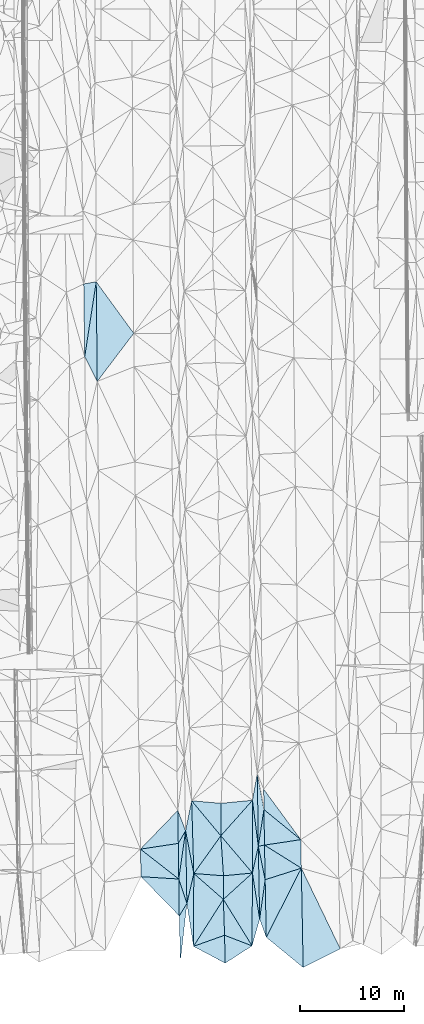
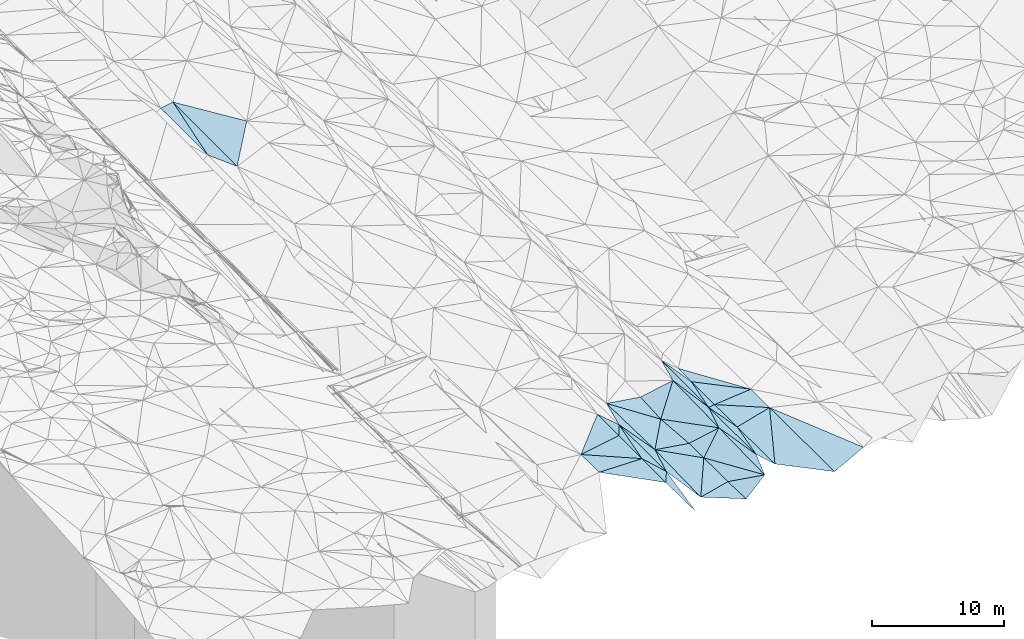
# One storey, part 23 of 275: 45 plates.
"""IFC2X3 building model written with IfcOpenShell, lengths in millimetres."""

from ifc_helpers import new_model, si_unit, frame, origin_with_axes, place, context, subcontext, project, spatial, polyline, outline, extrude, material, type_object, element, save


model = new_model("IFC2X3")

# Units and contexts
model_context = context("Model", 3, precision=1e-05, world=origin_with_axes())
body_context = subcontext(model_context, "Body", "Model", "MODEL_VIEW")
ifc_project = project(units=[si_unit("LENGTHUNIT", "METRE", prefix="MILLI"), si_unit("AREAUNIT", "SQUARE_METRE"), si_unit("VOLUMEUNIT", "CUBIC_METRE"), si_unit("MASSUNIT", "GRAM", prefix="KILO"), si_unit("TIMEUNIT", "SECOND"), si_unit("PLANEANGLEUNIT", "RADIAN"), si_unit("SOLIDANGLEUNIT", "STERADIAN"), si_unit("THERMODYNAMICTEMPERATUREUNIT", "DEGREE_CELSIUS"), si_unit("LUMINOUSINTENSITYUNIT", "LUMEN")], contexts=[model_context])

# Site, building, storey
site_placement = place(None, origin_with_axes())
site = spatial("IfcSite", under=ifc_project, at=site_placement, CompositionType="ELEMENT")
building_placement = place(site_placement, origin_with_axes())
building = spatial("IfcBuilding", under=site, at=building_placement, Name="Undefined", CompositionType="ELEMENT")
storey_placement = place(building_placement, origin_with_axes())
storey = spatial("IfcBuildingStorey", under=building, at=storey_placement, Name="Undefined", CompositionType="ELEMENT", Elevation=0.0)

# Plates
ifc_material = material()
plate_type_1 = type_object("IfcPlateType", PredefinedType="NOTDEFINED")
plate_1_placement = place(storey_placement, frame((-77855.6958797632, -26842.6024537685, 40772.5003564228), z_axis=(-0.033095411914403, 0.0193857631481733, -0.999264172227434), x_axis=(-0.152939120437254, 0.987938493469123, 0.0242313549319789)))
element("IfcPlate", 1, at=plate_1_placement, inside=storey, type_object=plate_type_1, material=ifc_material, Name="00", context=body_context, shape_type="SweptSolid", body=[
    extrude(outline(polyline([(0.0, 0.0), (4168.1533203125, 1.86264514923096e-09), (6918.4853515625, 1097.97338867188), (0.0, 0.0)])), frame((-8.85201319254618e-08, 2.18876761149539e-07, -0.5000001331573), z_axis=(0.0, 0.0, 1.0), x_axis=(1.0, 0.0, 0.0)), (0.0, 0.0, 1.0), 1.0),
])
plate_type_2 = type_object("IfcPlateType", PredefinedType="NOTDEFINED")
plate_2_placement = place(storey_placement, frame((-77855.7211969945, -26842.6145906234, 40772.5017499971), z_axis=(-0.0837460979317346, -0.0048636463274129, -0.996475256103036), x_axis=(0.93848230797332, 0.335810797561215, -0.0805112778582659)))
element("IfcPlate", 2, at=plate_2_placement, inside=storey, type_object=plate_type_2, material=ifc_material, Name="00", context=body_context, shape_type="SweptSolid", body=[
    extrude(outline(polyline([(0.0, 0.0), (3179.6787109375, 5.58247847948223e-09), (2334.474609375, 2548.92016601563), (0.0, 0.0)])), frame((-8.85201319254618e-08, 2.18876761149539e-07, -0.5000001331573), z_axis=(0.0, 0.0, 1.0), x_axis=(1.0, 0.0, 0.0)), (0.0, 0.0, 1.0), 1.0),
])
plate_type_3 = type_object("IfcPlateType", PredefinedType="NOTDEFINED")
plate_3_placement = place(storey_placement, frame((-79274.0806693137, -20367.1746317346, 40909.5004607387), z_axis=(0.0371895373784289, 0.0230456718728641, -0.999042459216577), x_axis=(0.0132180246697055, -0.999657930020083, -0.0225678260316448)))
element("IfcPlate", 3, at=plate_3_placement, inside=storey, type_object=plate_type_3, material=ifc_material, Name="00", context=body_context, shape_type="SweptSolid", body=[
    extrude(outline(polyline([(0.0, 0.0), (3544.86962890625, -8.73114913702011e-10), (-266.328552246094, 3628.7421875), (0.0, 0.0)])), frame((-8.85201319254618e-08, 2.18876761149539e-07, -0.5000001331573), z_axis=(0.0, 0.0, 1.0), x_axis=(1.0, 0.0, 0.0)), (0.0, 0.0, 1.0), 1.0),
])
plate_type_4 = type_object("IfcPlateType", PredefinedType="NOTDEFINED")
plate_4_placement = place(storey_placement, frame((-71497.0149106165, -24222.795486387, 40919.5004961251), z_axis=(-0.0398771542731156, 0.0213925396553267, -0.998975561169628), x_axis=(-0.0181141316664564, 0.999591013586829, 0.0221288000222636)))
element("IfcPlate", 4, at=plate_4_placement, inside=storey, type_object=plate_type_4, material=ifc_material, Name="00", context=body_context, shape_type="SweptSolid", body=[
    extrude(outline(polyline([(0.0, 0.0), (7004.44677734375, -7.04312697052956e-09), (3778.73461914063, 598.349670410156), (0.0, 0.0)])), frame((-8.85201319254618e-08, 2.18876761149539e-07, -0.5000001331573), z_axis=(0.0, 0.0, 1.0), x_axis=(1.0, 0.0, 0.0)), (0.0, 0.0, 1.0), 1.0),
])
plate_type_5 = type_object("IfcPlateType", PredefinedType="NOTDEFINED")
plate_5_placement = place(storey_placement, frame((-77829.3709402771, -19838.886317341, 40907.501097027), z_axis=(-0.0647328261765514, 0.0154924246653393, -0.997782364041971), x_axis=(-0.188330011545863, 0.981721795944408, 0.0274612839980644)))
element("IfcPlate", 5, at=plate_5_placement, inside=storey, type_object=plate_type_5, material=ifc_material, Name="00", context=body_context, shape_type="SweptSolid", body=[
    extrude(outline(polyline([(0.0, 0.0), (4187.7138671875, 8.14907252788544e-10), (6906.92578125, 1116.12890625), (0.0, 0.0)])), frame((-8.85201319254618e-08, 2.18876761149539e-07, -0.5000001331573), z_axis=(0.0, 0.0, 1.0), x_axis=(1.0, 0.0, 0.0)), (0.0, 0.0, 1.0), 1.0),
])
plate_type_6 = type_object("IfcPlateType", PredefinedType="NOTDEFINED")
plate_6_placement = place(storey_placement, frame((-78618.0011551694, -15727.7133152952, 41022.5001916065), z_axis=(0.0192150721586178, 0.0216287812629123, -0.999581400798865), x_axis=(0.0178375636637127, -0.999614276621159, -0.0212865990167345)))
element("IfcPlate", 6, at=plate_6_placement, inside=storey, type_object=plate_type_6, material=ifc_material, Name="00", context=body_context, shape_type="SweptSolid", body=[
    extrude(outline(polyline([(0.0, 0.0), (6999.708984375, 2.53203324973583e-09), (4628.375, 738.901428222656), (0.0, 0.0)])), frame((-8.85201319254618e-08, 2.18876761149539e-07, -0.5000001331573), z_axis=(0.0, 0.0, 1.0), x_axis=(1.0, 0.0, 0.0)), (0.0, 0.0, 1.0), 1.0),
])
plate_type_7 = type_object("IfcPlateType", PredefinedType="NOTDEFINED")
plate_7_placement = place(storey_placement, frame((-88318.7910822436, 29860.7643873985, 41740.5001281014), z_axis=(0.0135979427870087, 0.0199769013971401, -0.99970796703964), x_axis=(0.151373224421463, 0.988236114447613, 0.0218066281147447)))
element("IfcPlate", 7, at=plate_7_placement, inside=storey, type_object=plate_type_7, material=ifc_material, Name="00", context=body_context, shape_type="SweptSolid", body=[
    extrude(outline(polyline([(0.0, 0.0), (7291.36083984375, -1.16560840979218e-08), (-2161.79174804688, 1549.96850585938), (0.0, 0.0)])), frame((-8.85201319254618e-08, 2.18876761149539e-07, -0.5000001331573), z_axis=(0.0, 0.0, 1.0), x_axis=(1.0, 0.0, 0.0)), (0.0, 0.0, 1.0), 1.0),
])
plate_type_8 = type_object("IfcPlateType", PredefinedType="NOTDEFINED")
plate_8_placement = place(storey_placement, frame((-71623.8973660095, -17221.214263376, 41074.5006067428), z_axis=(-0.0458371674567032, 0.0196819527366252, -0.998755012410961), x_axis=(0.150292055395648, 0.988561557494762, 0.0125835260750638)))
element("IfcPlate", 8, at=plate_8_placement, inside=storey, type_object=plate_type_8, material=ifc_material, Name="00", context=body_context, shape_type="SweptSolid", body=[
    extrude(outline(polyline([(0.0, 0.0), (3576.10424804688, 6.14090822637081e-09), (204.144485473633, 571.127868652344), (0.0, 0.0)])), frame((-8.85201319254618e-08, 2.18876761149539e-07, -0.5000001331573), z_axis=(0.0, 0.0, 1.0), x_axis=(1.0, 0.0, 0.0)), (0.0, 0.0, 1.0), 1.0),
])
plate_type_9 = type_object("IfcPlateType", PredefinedType="NOTDEFINED")
plate_9_placement = place(storey_placement, frame((-71086.4392700437, -13686.0147237305, 41119.5007072906), z_axis=(-0.0497807695671621, 0.0202789475085021, -0.99855427457362), x_axis=(-0.150292055394831, -0.988561557494829, -0.0125835260795822)))
element("IfcPlate", 9, at=plate_9_placement, inside=storey, type_object=plate_type_9, material=ifc_material, Name="00", context=body_context, shape_type="SweptSolid", body=[
    extrude(outline(polyline([(0.0, 0.0), (3576.10424804688, 6.14090822637081e-09), (-3328.9501953125, 1150.23120117188), (0.0, 0.0)])), frame((-8.85201319254618e-08, 2.18876761149539e-07, -0.5000001331573), z_axis=(0.0, 0.0, 1.0), x_axis=(1.0, 0.0, 0.0)), (0.0, 0.0, 1.0), 1.0),
])
plate_type_10 = type_object("IfcPlateType", PredefinedType="NOTDEFINED")
plate_10_placement = place(storey_placement, frame((-71029.176936046, -17104.8038131413, 41049.500402141), z_axis=(-0.0347167280782452, 0.0211819655185762, -0.999172694346834), x_axis=(0.988399856173153, 0.14863653956921, -0.0311913998047732)))
element("IfcPlate", 10, at=plate_10_placement, inside=storey, type_object=plate_type_10, material=ifc_material, Name="00", context=body_context, shape_type="SweptSolid", body=[
    extrude(outline(polyline([(0.0, 0.0), (3526.61303710938, -1.44609657581896e-09), (3173.72485351563, 2720.9501953125), (0.0, 0.0)])), frame((-8.85201319254618e-08, 2.18876761149539e-07, -0.5000001331573), z_axis=(0.0, 0.0, 1.0), x_axis=(1.0, 0.0, 0.0)), (0.0, 0.0, 1.0), 1.0),
])
plate_11_placement = place(storey_placement, frame((-74810.820337492, -28459.5414804406, 40524.5035992951), z_axis=(0.119968344629757, -0.00024469578476659, -0.992777687305053), x_axis=(-0.0226136825509938, 0.999739839398053, -0.00297907399008728)))
element("IfcPlate", 11, at=plate_11_placement, inside=storey, type_object=plate_type_10, material=ifc_material, Name="00", context=body_context, shape_type="SweptSolid", body=[
    extrude(outline(polyline([(0.0, 0.0), (2685.39819335938, -4.05998434871435e-09), (1605.75207519531, 2641.36938476563), (0.0, 0.0)])), frame((-8.85201319254618e-08, 2.18876761149539e-07, -0.5000001331573), z_axis=(0.0, 0.0, 1.0), x_axis=(1.0, 0.0, 0.0)), (0.0, 0.0, 1.0), 1.0),
])
plate_type_11 = type_object("IfcPlateType", PredefinedType="NOTDEFINED")
plate_12_placement = place(storey_placement, frame((-78493.1721763449, -22724.7228803627, 40873.500461501), z_axis=(-0.0383433297001515, 0.0205904197820008, -0.999052462927101), x_axis=(-0.0178375635316432, 0.999614276623936, 0.0212865989970147)))
element("IfcPlate", 12, at=plate_12_placement, inside=storey, type_object=plate_type_11, material=ifc_material, Name="00", context=body_context, shape_type="SweptSolid", body=[
    extrude(outline(polyline([(0.0, 0.0), (6999.708984375, 2.53203324973583e-09), (2873.60888671875, 715.712890625), (0.0, 0.0)])), frame((-8.85201319254618e-08, 2.18876761149539e-07, -0.5000001331573), z_axis=(0.0, 0.0, 1.0), x_axis=(1.0, 0.0, 0.0)), (0.0, 0.0, 1.0), 1.0),
])
plate_type_12 = type_object("IfcPlateType", PredefinedType="NOTDEFINED")
plate_13_placement = place(storey_placement, frame((-79368.7672431156, -13772.3030256395, 41049.5002324783), z_axis=(0.0223576649135496, 0.0223850226259977, -0.999499397489387), x_axis=(0.358403135514181, -0.933477936474616, -0.0128893199469879)))
element("IfcPlate", 13, at=plate_13_placement, inside=storey, type_object=plate_type_12, material=ifc_material, Name="00", context=body_context, shape_type="SweptSolid", body=[
    extrude(outline(polyline([(0.0, 0.0), (2094.75756835938, 3.37604433298111e-09), (2978.62158203125, 1093.94384765625), (0.0, 0.0)])), frame((-8.85201319254618e-08, 2.18876761149539e-07, -0.5000001331573), z_axis=(0.0, 0.0, 1.0), x_axis=(1.0, 0.0, 0.0)), (0.0, 0.0, 1.0), 1.0),
])
plate_type_13 = type_object("IfcPlateType", PredefinedType="NOTDEFINED")
plate_14_placement = place(storey_placement, frame((-71623.7911505075, -17221.2125910866, 41074.5071102668), z_axis=(0.166597117976748, 0.0230386989947293, -0.985755861575508), x_axis=(-0.126567595564065, 0.991956364182143, 0.00179312901802421)))
element("IfcPlate", 14, at=plate_14_placement, inside=storey, type_object=plate_type_13, material=ifc_material, Name="00", context=body_context, shape_type="SweptSolid", body=[
    extrude(outline(polyline([(0.0, 0.0), (4461.47607421875, 1.00480974651873e-08), (6954.34326171875, 799.949768066406), (0.0, 0.0)])), frame((-8.85201319254618e-08, 2.18876761149539e-07, -0.5000001331573), z_axis=(0.0, 0.0, 1.0), x_axis=(1.0, 0.0, 0.0)), (0.0, 0.0, 1.0), 1.0),
])
plate_type_14 = type_object("IfcPlateType", PredefinedType="NOTDEFINED")
plate_15_placement = place(storey_placement, frame((-74985.6070153125, -22326.5048611658, 40667.5032578217), z_axis=(0.112643869316624, -0.0186240469920938, -0.99346087168998), x_axis=(0.00598911346132977, 0.999818891903969, -0.0180641609787954)))
element("IfcPlate", 15, at=plate_15_placement, inside=storey, type_object=plate_type_14, material=ifc_material, Name="00", context=body_context, shape_type="SweptSolid", body=[
    extrude(outline(polyline([(0.0, 0.0), (2269.6875, -1.73167791217566e-09), (2547.8447265625, 2794.38208007813), (0.0, 0.0)])), frame((-8.85201319254618e-08, 2.18876761149539e-07, -0.5000001331573), z_axis=(0.0, 0.0, 1.0), x_axis=(1.0, 0.0, 0.0)), (0.0, 0.0, 1.0), 1.0),
])
plate_type_15 = type_object("IfcPlateType", PredefinedType="NOTDEFINED")
plate_16_placement = place(storey_placement, frame((-77829.3881603102, -19838.9027542349, 40907.5025287368), z_axis=(-0.0991740370332565, -0.0173815474116761, -0.994918284176194), x_axis=(0.992333852326071, -0.0758246544790692, -0.0975917378717536)))
element("IfcPlate", 16, at=plate_16_placement, inside=storey, type_object=plate_type_15, material=ifc_material, Name="00", context=body_context, shape_type="SweptSolid", body=[
    extrude(outline(polyline([(0.0, 0.0), (2879.34204101563, -7.95989762991667e-09), (3033.91870117188, 2264.41748046875), (0.0, 0.0)])), frame((-8.85201319254618e-08, 2.18876761149539e-07, -0.5000001331573), z_axis=(0.0, 0.0, 1.0), x_axis=(1.0, 0.0, 0.0)), (0.0, 0.0, 1.0), 1.0),
])
plate_type_16 = type_object("IfcPlateType", PredefinedType="NOTDEFINED")
plate_17_placement = place(storey_placement, frame((-72225.5477975187, -26793.956314234, 40836.5010762002), z_axis=(0.0644252455107256, 0.0139548846897058, -0.997824959065557), x_axis=(0.00452874345366986, 0.999887834920917, 0.0142761360280655)))
element("IfcPlate", 17, at=plate_17_placement, inside=storey, type_object=plate_type_16, material=ifc_material, Name="00", context=body_context, shape_type="SweptSolid", body=[
    extrude(outline(polyline([(0.0, 0.0), (7004.6962890625, -4.52564563602209e-09), (2575.35327148438, 718.421813964844), (0.0, 0.0)])), frame((-8.85201319254618e-08, 2.18876761149539e-07, -0.5000001331573), z_axis=(0.0, 0.0, 1.0), x_axis=(1.0, 0.0, 0.0)), (0.0, 0.0, 1.0), 1.0),
])
plate_type_17 = type_object("IfcPlateType", PredefinedType="NOTDEFINED")
plate_18_placement = place(storey_placement, frame((-71110.0004458326, -11728.3748281446, 41169.500371023), z_axis=(-0.0302119965966342, 0.0251574759713925, -0.999226869466786), x_axis=(0.591819216411072, -0.805166696416169, -0.038165508890328)))
element("IfcPlate", 18, at=plate_18_placement, inside=storey, type_object=plate_type_17, material=ifc_material, Name="00", context=body_context, shape_type="SweptSolid", body=[
    extrude(outline(polyline([(0.0, 0.0), (6026.3837890625, 9.60426405072212e-09), (1592.08251953125, 1140.470703125), (0.0, 0.0)])), frame((-8.85201319254618e-08, 2.18876761149539e-07, -0.5000001331573), z_axis=(0.0, 0.0, 1.0), x_axis=(1.0, 0.0, 0.0)), (0.0, 0.0, 1.0), 1.0),
])
plate_type_18 = type_object("IfcPlateType", PredefinedType="NOTDEFINED")
plate_19_placement = place(storey_placement, frame((-79123.1943218423, -28325.7704882602, 40739.5002608361), z_axis=(0.0259955898751133, 0.0209865299572828, -0.999441741607482), x_axis=(-0.0235530626558573, 0.999514929511707, 0.0203754490192606)))
element("IfcPlate", 19, at=plate_19_placement, inside=storey, type_object=plate_type_18, material=ifc_material, Name="00", context=body_context, shape_type="SweptSolid", body=[
    extrude(outline(polyline([(0.0, 0.0), (4417.08056640625, -6.85395207256079e-09), (5586.2216796875, 762.095947265625), (0.0, 0.0)])), frame((-8.85201319254618e-08, 2.18876761149539e-07, -0.5000001331573), z_axis=(0.0, 0.0, 1.0), x_axis=(1.0, 0.0, 0.0)), (0.0, 0.0, 1.0), 1.0),
])
plate_20_placement = place(storey_placement, frame((-70967.6909339628, -20434.2515424513, 40979.500613451), z_axis=(-0.0459281768087278, 0.0201498037241235, -0.998741502083951), x_axis=(-0.200017944623415, 0.979364242674647, 0.0289568989869318)))
element("IfcPlate", 20, at=plate_20_placement, inside=storey, type_object=plate_type_18, material=ifc_material, Name="00", context=body_context, shape_type="SweptSolid", body=[
    extrude(outline(polyline([(0.0, 0.0), (3280.73803710938, 3.68163455277681e-09), (3275.06787109375, 606.489807128906), (0.0, 0.0)])), frame((-8.85201319254618e-08, 2.18876761149539e-07, -0.5000001331573), z_axis=(0.0, 0.0, 1.0), x_axis=(1.0, 0.0, 0.0)), (0.0, 0.0, 1.0), 1.0),
])
plate_type_19 = type_object("IfcPlateType", PredefinedType="NOTDEFINED")
plate_21_placement = place(storey_placement, frame((-72193.7840856635, -19790.0424241143, 40936.5055202208), z_axis=(0.146901939891898, 0.020531466156136, -0.988937955057584), x_axis=(0.000758266462155232, 0.99978192623181, 0.0208692360229906)))
element("IfcPlate", 21, at=plate_21_placement, inside=storey, type_object=plate_type_19, material=ifc_material, Name="00", context=body_context, shape_type="SweptSolid", body=[
    extrude(outline(polyline([(0.0, 0.0), (6995.94384765625, -7.47240846976638e-09), (2571.58056640625, 574.263488769531), (0.0, 0.0)])), frame((-8.85201319254618e-08, 2.18876761149539e-07, -0.5000001331573), z_axis=(0.0, 0.0, 1.0), x_axis=(1.0, 0.0, 0.0)), (0.0, 0.0, 1.0), 1.0),
])
plate_type_20 = type_object("IfcPlateType", PredefinedType="NOTDEFINED")
plate_22_placement = place(storey_placement, frame((-82903.5155905357, -20145.8103126562, 40779.5004644065), z_axis=(0.0372109465557981, 0.0234020185282223, -0.999033378313871), x_axis=(-0.0217524866509341, 0.999507847581099, 0.022602919021669)))
element("IfcPlate", 22, at=plate_22_placement, inside=storey, type_object=plate_type_20, material=ifc_material, Name="00", context=body_context, shape_type="SweptSolid", body=[
    extrude(outline(polyline([(0.0, 0.0), (2654.5244140625, -8.73114913702011e-11), (-297.266052246094, 3626.3388671875), (0.0, 0.0)])), frame((-8.85201319254618e-08, 2.18876761149539e-07, -0.5000001331573), z_axis=(0.0, 0.0, 1.0), x_axis=(1.0, 0.0, 0.0)), (0.0, 0.0, 1.0), 1.0),
])
plate_type_21 = type_object("IfcPlateType", PredefinedType="NOTDEFINED")
plate_23_placement = place(storey_placement, frame((-70858.744125949, -25973.1898214341, 40869.500236894), z_axis=(-0.0252228838304343, 0.0193532955014952, -0.999494500277269), x_axis=(-0.342452438561852, 0.93915208856692, 0.0268268869500915)))
element("IfcPlate", 23, at=plate_23_placement, inside=storey, type_object=plate_type_21, material=ifc_material, Name="00", context=body_context, shape_type="SweptSolid", body=[
    extrude(outline(polyline([(0.0, 0.0), (1863.8017578125, 2.27009877562523e-09), (5242.16162109375, 1795.42248535156), (0.0, 0.0)])), frame((-8.85201319254618e-08, 2.18876761149539e-07, -0.5000001331573), z_axis=(0.0, 0.0, 1.0), x_axis=(1.0, 0.0, 0.0)), (0.0, 0.0, 1.0), 1.0),
])
plate_type_22 = type_object("IfcPlateType", PredefinedType="NOTDEFINED")
plate_24_placement = place(storey_placement, frame((-79274.0877844012, -20367.1747208126, 40909.5002445214), z_axis=(0.0229587654083464, 0.0228672670043347, -0.999474853706024), x_axis=(0.314417484493332, -0.949174151361683, -0.0144939929527196)))
element("IfcPlate", 24, at=plate_24_placement, inside=storey, type_object=plate_type_22, material=ifc_material, Name="00", context=body_context, shape_type="SweptSolid", body=[
    extrude(outline(polyline([(0.0, 0.0), (2483.78759765625, -3.49245965480804e-10), (3379.439453125, 1070.27502441406), (0.0, 0.0)])), frame((-8.85201319254618e-08, 2.18876761149539e-07, -0.5000001331573), z_axis=(0.0, 0.0, 1.0), x_axis=(1.0, 0.0, 0.0)), (0.0, 0.0, 1.0), 1.0),
])
plate_type_23 = type_object("IfcPlateType", PredefinedType="NOTDEFINED")
plate_25_placement = place(storey_placement, frame((-71496.9297592527, -24222.7940366167, 40919.504409294), z_axis=(0.130429758441461, 0.0243057343224944, -0.99115957816688), x_axis=(-0.155299140536863, 0.987860224921203, 0.00378853100047694)))
element("IfcPlate", 25, at=plate_25_placement, inside=storey, type_object=plate_type_23, material=ifc_material, Name="00", context=body_context, shape_type="SweptSolid", body=[
    extrude(outline(polyline([(0.0, 0.0), (4487.2275390625, -1.42608769237995e-09), (6936.8759765625, 970.580810546875), (0.0, 0.0)])), frame((-8.85201319254618e-08, 2.18876761149539e-07, -0.5000001331573), z_axis=(0.0, 0.0, 1.0), x_axis=(1.0, 0.0, 0.0)), (0.0, 0.0, 1.0), 1.0),
])
plate_type_24 = type_object("IfcPlateType", PredefinedType="NOTDEFINED")
plate_26_placement = place(storey_placement, frame((-75201.092081701, -13084.3520568936, 40769.5023957516), z_axis=(-0.0875651220301761, 0.044034452178201, -0.995185066419913), x_axis=(-0.0087707684540865, -0.999017871529459, -0.0434323149909625)))
element("IfcPlate", 26, at=plate_26_placement, inside=storey, type_object=plate_type_24, material=ifc_material, Name="00", context=body_context, shape_type="SweptSolid", body=[
    extrude(outline(polyline([(0.0, 0.0), (3131.30908203125, -4.36557456851006e-11), (-224.069229125977, 2848.31494140625), (0.0, 0.0)])), frame((-8.85201319254618e-08, 2.18876761149539e-07, -0.5000001331573), z_axis=(0.0, 0.0, 1.0), x_axis=(1.0, 0.0, 0.0)), (0.0, 0.0, 1.0), 1.0),
])
plate_type_25 = type_object("IfcPlateType", PredefinedType="NOTDEFINED")
plate_27_placement = place(storey_placement, frame((-74985.7131821982, -22326.475430147, 40667.5028859701), z_axis=(-0.0996897330681453, 0.0402380315601238, -0.994204635845643), x_axis=(0.0330259535576184, -0.998497650267673, -0.0437233210260437)))
element("IfcPlate", 27, at=plate_27_placement, inside=storey, type_object=plate_type_25, material=ifc_material, Name="00", context=body_context, shape_type="SweptSolid", body=[
    extrude(outline(polyline([(0.0, 0.0), (3453.53466796875, 2.25554686039686e-09), (4409.9560546875, 3032.42724609375), (0.0, 0.0)])), frame((-8.85201319254618e-08, 2.18876761149539e-07, -0.5000001331573), z_axis=(0.0, 0.0, 1.0), x_axis=(1.0, 0.0, 0.0)), (0.0, 0.0, 1.0), 1.0),
])
plate_type_26 = type_object("IfcPlateType", PredefinedType="NOTDEFINED")
plate_28_placement = place(storey_placement, frame((-88318.7925798816, 29860.7646170594, 41740.5001145802), z_axis=(0.0106034422808835, 0.0204361798028466, -0.999734929652286), x_axis=(-0.0137492026408672, 0.999699600048951, 0.0202896300781234)))
element("IfcPlate", 28, at=plate_28_placement, inside=storey, type_object=plate_type_26, material=ifc_material, Name="00", context=body_context, shape_type="SweptSolid", body=[
    extrude(outline(polyline([(0.0, 0.0), (6998.64892578125, -2.22644302994013e-09), (7191.47265625, 1202.77514648438), (0.0, 0.0)])), frame((-8.85201319254618e-08, 2.18876761149539e-07, -0.5000001331573), z_axis=(0.0, 0.0, 1.0), x_axis=(1.0, 0.0, 0.0)), (0.0, 0.0, 1.0), 1.0),
])
plate_type_27 = type_object("IfcPlateType", PredefinedType="NOTDEFINED")
plate_29_placement = place(storey_placement, frame((-79368.7609103637, -13772.3029297343, 41049.500422106), z_axis=(0.035038675280852, 0.0225630743515077, -0.999131222067638), x_axis=(0.0146763875075118, -0.999648916697277, -0.0220600769647263)))
element("IfcPlate", 29, at=plate_29_placement, inside=storey, type_object=plate_type_27, material=ifc_material, Name="00", context=body_context, shape_type="SweptSolid", body=[
    extrude(outline(polyline([(0.0, 0.0), (3173.15307617188, -1.04773789644241e-09), (3670.89135742188, 3649.00756835938), (0.0, 0.0)])), frame((-8.85201319254618e-08, 2.18876761149539e-07, -0.5000001331573), z_axis=(0.0, 0.0, 1.0), x_axis=(1.0, 0.0, 0.0)), (0.0, 0.0, 1.0), 1.0),
])
plate_type_28 = type_object("IfcPlateType", PredefinedType="NOTDEFINED")
plate_30_placement = place(storey_placement, frame((-79274.0867107654, -20367.1757580355, 40909.5002477707), z_axis=(0.0251064545213819, 0.0207929037759799, -0.999468519311103), x_axis=(-0.0140509126637282, 0.999692247694972, 0.0204446020233064)))
element("IfcPlate", 30, at=plate_30_placement, inside=storey, type_object=plate_type_28, material=ifc_material, Name="00", context=body_context, shape_type="SweptSolid", body=[
    extrude(outline(polyline([(0.0, 0.0), (3423.88671875, -6.37373887002468e-09), (4631.1259765625, 721.458679199219), (0.0, 0.0)])), frame((-8.85201319254618e-08, 2.18876761149539e-07, -0.5000001331573), z_axis=(0.0, 0.0, 1.0), x_axis=(1.0, 0.0, 0.0)), (0.0, 0.0, 1.0), 1.0),
])
plate_type_29 = type_object("IfcPlateType", PredefinedType="NOTDEFINED")
plate_31_placement = place(storey_placement, frame((-67489.9662932521, -19323.1810070309, 40879.5003581568), z_axis=(-0.0326259604196101, 0.020310079486553, -0.999261250813794), x_axis=(0.434673031688406, -0.900002276178725, -0.0324847409705625)))
element("IfcPlate", 31, at=plate_31_placement, inside=storey, type_object=plate_type_29, material=ifc_material, Name="00", context=body_context, shape_type="SweptSolid", body=[
    extrude(outline(polyline([(0.0, 0.0), (8619.431640625, -2.68773874267936e-08), (8682.37109375, 3995.31469726563), (0.0, 0.0)])), frame((-8.85201319254618e-08, 2.18876761149539e-07, -0.5000001331573), z_axis=(0.0, 0.0, 1.0), x_axis=(1.0, 0.0, 0.0)), (0.0, 0.0, 1.0), 1.0),
])
plate_type_30 = type_object("IfcPlateType", PredefinedType="NOTDEFINED")
plate_32_placement = place(storey_placement, frame((-87215.0700557721, 37066.3507431017, 41899.500203614), z_axis=(0.0219812784310495, 0.0200623275241233, -0.999557065110768), x_axis=(0.589121532646521, -0.808037853766416, -0.00326292089682773)))
element("IfcPlate", 32, at=plate_32_placement, inside=storey, type_object=plate_type_30, material=ifc_material, Name="00", context=body_context, shape_type="SweptSolid", body=[
    extrude(outline(polyline([(0.0, 0.0), (6129.47802734375, 1.84736563824117e-08), (7798.673828125, 5562.83984375), (0.0, 0.0)])), frame((-8.85201319254618e-08, 2.18876761149539e-07, -0.5000001331573), z_axis=(0.0, 0.0, 1.0), x_axis=(1.0, 0.0, 0.0)), (0.0, 0.0, 1.0), 1.0),
])
plate_type_31 = type_object("IfcPlateType", PredefinedType="NOTDEFINED")
plate_33_placement = place(storey_placement, frame((-71086.4316410155, -13686.0149227535, 41119.5003812624), z_axis=(-0.034522097162634, 0.0198806844666048, -0.999206176518457), x_axis=(0.773806049519148, -0.632201446552037, -0.0393132128562664)))
element("IfcPlate", 33, at=plate_33_placement, inside=storey, type_object=plate_type_31, material=ifc_material, Name="00", context=body_context, shape_type="SweptSolid", body=[
    extrude(outline(polyline([(0.0, 0.0), (4578.61328125, -1.16197043098509e-08), (2208.41967773438, 2611.3564453125), (0.0, 0.0)])), frame((-8.85201319254618e-08, 2.18876761149539e-07, -0.5000001331573), z_axis=(0.0, 0.0, 1.0), x_axis=(1.0, 0.0, 0.0)), (0.0, 0.0, 1.0), 1.0),
])
plate_type_32 = type_object("IfcPlateType", PredefinedType="NOTDEFINED")
plate_34_placement = place(storey_placement, frame((-70858.7489407645, -25973.189919532, 40869.5003800583), z_axis=(-0.0348524606216054, 0.0191582343102801, -0.999208821041294), x_axis=(-0.0196597126645682, 0.999609627629272, 0.0198516510350018)))
element("IfcPlate", 34, at=plate_34_placement, inside=storey, type_object=plate_type_32, material=ifc_material, Name="00", context=body_context, shape_type="SweptSolid", body=[
    extrude(outline(polyline([(0.0, 0.0), (5541.10107421875, -8.42555891722441e-09), (6581.3818359375, 3500.9736328125), (0.0, 0.0)])), frame((-8.85201319254618e-08, 2.18876761149539e-07, -0.5000001331573), z_axis=(0.0, 0.0, 1.0), x_axis=(1.0, 0.0, 0.0)), (0.0, 0.0, 1.0), 1.0),
])
plate_type_33 = type_object("IfcPlateType", PredefinedType="NOTDEFINED")
plate_35_placement = place(storey_placement, frame((-67489.9684621391, -19323.1810485953, 40879.5004331385), z_axis=(-0.036960712377621, 0.0202260929208925, -0.999112011190785), x_axis=(0.0186471675392509, -0.999607116888856, -0.0209259410281103)))
element("IfcPlate", 35, at=plate_35_placement, inside=storey, type_object=plate_type_33, material=ifc_material, Name="00", context=body_context, shape_type="SweptSolid", body=[
    extrude(outline(polyline([(0.0, 0.0), (9557.515625, 1.70111889019609e-08), (6584.78662109375, 3494.56494140625), (0.0, 0.0)])), frame((-8.85201319254618e-08, 2.18876761149539e-07, -0.5000001331573), z_axis=(0.0, 0.0, 1.0), x_axis=(1.0, 0.0, 0.0)), (0.0, 0.0, 1.0), 1.0),
])
plate_type_34 = type_object("IfcPlateType", PredefinedType="NOTDEFINED")
plate_36_placement = place(storey_placement, frame((-71029.177194637, -17104.8042260926, 41049.5004025076), z_axis=(-0.035234173860626, 0.0203563571689376, -0.999171742852634), x_axis=(0.846611224494961, -0.530655959669295, -0.0406655508582163)))
element("IfcPlate", 36, at=plate_36_placement, inside=storey, type_object=plate_type_34, material=ifc_material, Name="00", context=body_context, shape_type="SweptSolid", body=[
    extrude(outline(polyline([(0.0, 0.0), (4180.4423828125, -2.46582203544676e-08), (1821.69702148438, 2788.42602539063), (0.0, 0.0)])), frame((-8.85201319254618e-08, 2.18876761149539e-07, -0.5000001331573), z_axis=(0.0, 0.0, 1.0), x_axis=(1.0, 0.0, 0.0)), (0.0, 0.0, 1.0), 1.0),
])
plate_type_35 = type_object("IfcPlateType", PredefinedType="NOTDEFINED")
plate_37_placement = place(storey_placement, frame((-74972.0149123523, -20057.2146104319, 40626.503044869), z_axis=(0.110020726059108, 0.00914817664301516, -0.993887192140806), x_axis=(-0.0665537655707274, 0.997781186395975, 0.00181669001114636)))
element("IfcPlate", 37, at=plate_37_placement, inside=storey, type_object=plate_type_35, material=ifc_material, Name="00", context=body_context, shape_type="SweptSolid", body=[
    extrude(outline(polyline([(0.0, 0.0), (3853.16088867188, -3.17231751978397e-09), (82.2363815307617, 2806.98754882813), (0.0, 0.0)])), frame((-8.85201319254618e-08, 2.18876761149539e-07, -0.5000001331573), z_axis=(0.0, 0.0, 1.0), x_axis=(1.0, 0.0, 0.0)), (0.0, 0.0, 1.0), 1.0),
])
plate_type_36 = type_object("IfcPlateType", PredefinedType="NOTDEFINED")
plate_38_placement = place(storey_placement, frame((-75228.4626728232, -16212.5865430683, 40633.502907465), z_axis=(0.0992349066759452, 0.0423500019944274, -0.99416241662421), x_axis=(0.00877076845361714, 0.999017871529039, 0.0434323150007147)))
element("IfcPlate", 38, at=plate_38_placement, inside=storey, type_object=plate_type_36, material=ifc_material, Name="00", context=body_context, shape_type="SweptSolid", body=[
    extrude(outline(polyline([(0.0, 0.0), (3131.30908203125, -4.36557456851006e-11), (3459.78125, 3024.6611328125), (0.0, 0.0)])), frame((-8.85201319254618e-08, 2.18876761149539e-07, -0.5000001331573), z_axis=(0.0, 0.0, 1.0), x_axis=(1.0, 0.0, 0.0)), (0.0, 0.0, 1.0), 1.0),
])
plate_type_37 = type_object("IfcPlateType", PredefinedType="NOTDEFINED")
plate_39_placement = place(storey_placement, frame((-72225.538298051, -26793.9563648983, 40836.5017800151), z_axis=(0.0834262355613961, 0.0138487332650739, -0.996417721544036), x_axis=(-0.525326357256377, 0.850292645405362, -0.0321657510606522)))
element("IfcPlate", 39, at=plate_39_placement, inside=storey, type_object=plate_type_37, material=ifc_material, Name="00", context=body_context, shape_type="SweptSolid", body=[
    extrude(outline(polyline([(0.0, 0.0), (5254.03564453125, 2.06637196242809e-08), (5935.49267578125, 3719.63696289063), (0.0, 0.0)])), frame((-8.85201319254618e-08, 2.18876761149539e-07, -0.5000001331573), z_axis=(0.0, 0.0, 1.0), x_axis=(1.0, 0.0, 0.0)), (0.0, 0.0, 1.0), 1.0),
])
plate_type_38 = type_object("IfcPlateType", PredefinedType="NOTDEFINED")
plate_40_placement = place(storey_placement, frame((-74985.6969086498, -22326.4858064247, 40667.5012120724), z_axis=(-0.0671497407809235, 0.0194808512307755, -0.997552709759429), x_axis=(-0.536256529484323, -0.843827013180178, 0.0196190319039853)))
element("IfcPlate", 40, at=plate_40_placement, inside=storey, type_object=plate_type_38, material=ifc_material, Name="00", context=body_context, shape_type="SweptSolid", body=[
    extrude(outline(polyline([(0.0, 0.0), (5351.94580078125, 1.0077201295644e-08), (-569.457336425781, 3742.72216796875), (0.0, 0.0)])), frame((-8.85201319254618e-08, 2.18876761149539e-07, -0.5000001331573), z_axis=(0.0, 0.0, 1.0), x_axis=(1.0, 0.0, 0.0)), (0.0, 0.0, 1.0), 1.0),
])
plate_type_39 = type_object("IfcPlateType", PredefinedType="NOTDEFINED")
plate_41_placement = place(storey_placement, frame((-75228.5614048982, -16212.610090416, 40633.5024121802), z_axis=(-0.0982311305457426, -0.00474028613078917, -0.995152337423323), x_axis=(0.0665537655718528, -0.997781186395893, -0.00181669001496357)))
element("IfcPlate", 41, at=plate_41_placement, inside=storey, type_object=plate_type_39, material=ifc_material, Name="00", context=body_context, shape_type="SweptSolid", body=[
    extrude(outline(polyline([(0.0, 0.0), (3853.16088867188, -3.17231751978397e-09), (3444.64770507813, 2850.21533203125), (0.0, 0.0)])), frame((-8.85201319254618e-08, 2.18876761149539e-07, -0.5000001331573), z_axis=(0.0, 0.0, 1.0), x_axis=(1.0, 0.0, 0.0)), (0.0, 0.0, 1.0), 1.0),
])
plate_type_40 = type_object("IfcPlateType", PredefinedType="NOTDEFINED")
plate_42_placement = place(storey_placement, frame((-82961.2590726918, -17492.5935364255, 40839.5004067794), z_axis=(0.0352857983853525, 0.0209296279953419, -0.999158077135087), x_axis=(0.988126107721543, 0.148868019512, 0.0380145762260796)))
element("IfcPlate", 42, at=plate_42_placement, inside=storey, type_object=plate_type_40, material=ifc_material, Name="00", context=body_context, shape_type="SweptSolid", body=[
    extrude(outline(polyline([(0.0, 0.0), (3682.7978515625, -7.77617970015854e-09), (3218.1240234375, 3392.20849609375), (0.0, 0.0)])), frame((-8.85201319254618e-08, 2.18876761149539e-07, -0.5000001331573), z_axis=(0.0, 0.0, 1.0), x_axis=(1.0, 0.0, 0.0)), (0.0, 0.0, 1.0), 1.0),
])
plate_type_41 = type_object("IfcPlateType", PredefinedType="NOTDEFINED")
plate_43_placement = place(storey_placement, frame((-75228.5740854171, -16212.6008843346, 40633.5038676215), z_axis=(-0.123571134185935, 0.0136538596651656, -0.992241778455355), x_axis=(-0.581717688577152, -0.811078742345868, 0.0612846188786493)))
element("IfcPlate", 43, at=plate_43_placement, inside=storey, type_object=plate_type_41, material=ifc_material, Name="00", context=body_context, shape_type="SweptSolid", body=[
    extrude(outline(polyline([(0.0, 0.0), (4470.9423828125, 5.18775777891278e-09), (-1072.5458984375, 4268.61865234375), (0.0, 0.0)])), frame((-8.85201319254618e-08, 2.18876761149539e-07, -0.5000001331573), z_axis=(0.0, 0.0, 1.0), x_axis=(1.0, 0.0, 0.0)), (0.0, 0.0, 1.0), 1.0),
])
plate_type_42 = type_object("IfcPlateType", PredefinedType="NOTDEFINED")
plate_44_placement = place(storey_placement, frame((-74871.5380352017, -25774.817747026, 40516.5053572911), z_axis=(0.138080881723207, 0.0478860429085491, -0.989262653190295), x_axis=(-0.033025953576171, 0.998497650268353, 0.0437233209964999)))
element("IfcPlate", 44, at=plate_44_placement, inside=storey, type_object=plate_type_42, material=ifc_material, Name="00", context=body_context, shape_type="SweptSolid", body=[
    extrude(outline(polyline([(0.0, 0.0), (3453.53466796875, 2.25554686039686e-09), (-1090.98657226563, 2636.70556640625), (0.0, 0.0)])), frame((-8.85201319254618e-08, 2.18876761149539e-07, -0.5000001331573), z_axis=(0.0, 0.0, 1.0), x_axis=(1.0, 0.0, 0.0)), (0.0, 0.0, 1.0), 1.0),
])
plate_type_43 = type_object("IfcPlateType", PredefinedType="NOTDEFINED")
plate_45_placement = place(storey_placement, frame((-72188.4910659833, -12795.6241891518, 41082.5039146554), z_axis=(0.123366333765533, 0.020616301703893, -0.992147023276946), x_axis=(-0.000758266417051466, -0.999781926232288, -0.0208692360017429)))
element("IfcPlate", 45, at=plate_45_placement, inside=storey, type_object=plate_type_43, material=ifc_material, Name="00", context=body_context, shape_type="SweptSolid", body=[
    extrude(outline(polyline([(0.0, 0.0), (6995.94384765625, -7.47240846976638e-09), (3427.90356445313, 3060.74145507813), (0.0, 0.0)])), frame((-8.85201319254618e-08, 2.18876761149539e-07, -0.5000001331573), z_axis=(0.0, 0.0, 1.0), x_axis=(1.0, 0.0, 0.0)), (0.0, 0.0, 1.0), 1.0),
])

save(model, "model.ifc")
